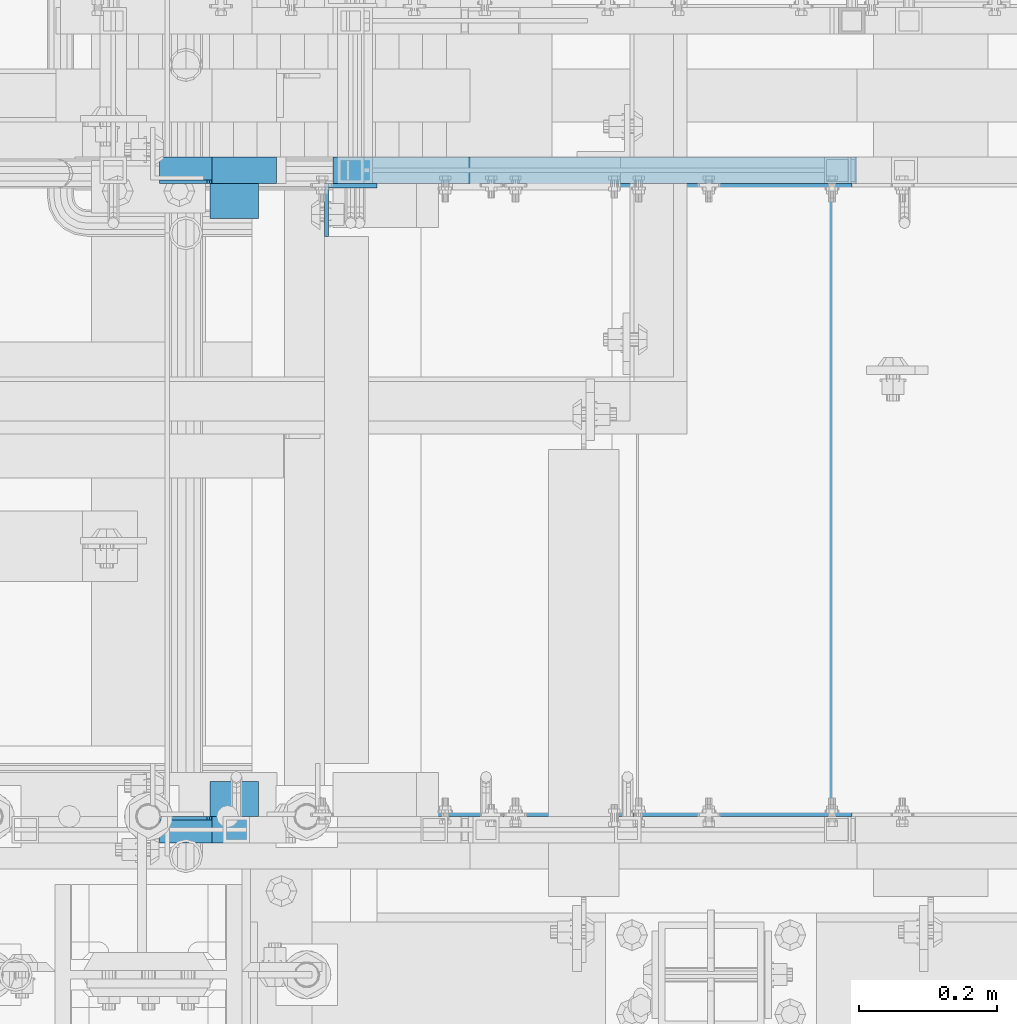
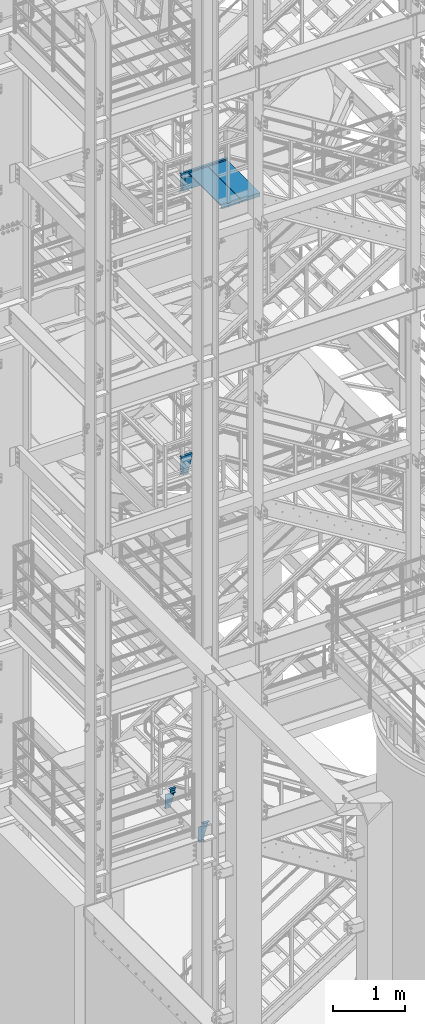
# One storey, part 1137 of 1876: 10 beams, 3 elements without a shape of their own.
"""IFC2X3 building model written with IfcOpenShell, lengths in millimetres."""

from ifc_helpers import new_model, si_unit, frame, origin_with_axes, place, context, subcontext, project, spatial, faceted_brep, material, type_object, element, aggregate, save


model = new_model("IFC2X3")

# Units and contexts
model_context = context("Model", 3, precision=1e-05, world=origin_with_axes())
body_context = subcontext(model_context, "Body", "Model", "MODEL_VIEW")
ifc_project = project(units=[si_unit("LENGTHUNIT", "METRE", prefix="MILLI"), si_unit("AREAUNIT", "SQUARE_METRE"), si_unit("VOLUMEUNIT", "CUBIC_METRE"), si_unit("MASSUNIT", "GRAM", prefix="KILO"), si_unit("TIMEUNIT", "SECOND"), si_unit("PLANEANGLEUNIT", "RADIAN"), si_unit("SOLIDANGLEUNIT", "STERADIAN"), si_unit("THERMODYNAMICTEMPERATUREUNIT", "DEGREE_CELSIUS"), si_unit("LUMINOUSINTENSITYUNIT", "LUMEN")], contexts=[model_context])

# Site, building, storey
site_placement = place(None, origin_with_axes())
site = spatial("IfcSite", under=ifc_project, at=site_placement, CompositionType="ELEMENT")
building_placement = place(site_placement, origin_with_axes())
building = spatial("IfcBuilding", under=site, at=building_placement, Name="Undefined", CompositionType="ELEMENT")
storey_placement = place(building_placement, origin_with_axes())
storey = spatial("IfcBuildingStorey", under=building, at=storey_placement, Name="Undefined", CompositionType="ELEMENT", Elevation=0.0)

# Assembly, beams
assembly_1_placement = place(storey_placement, origin_with_axes())
assembly_1 = element("IfcElementAssembly", 1, at=assembly_1_placement, inside=storey, Name="STRINGER", AssemblyPlace="NOTDEFINED", PredefinedType="RIGID_FRAME")
ifc_material = material(Name="STEEL/A36")
beam_type_1 = type_object("IfcBeamType", PredefinedType="NOTDEFINED")
beam_1_placement = place(assembly_1_placement, frame((2274.88754446459, -6878.63800737594, 15559.8610714293), z_axis=(1.0, 0.0, 0.0), x_axis=(0.0, 1.0, 0.0)))
beam_1 = element("IfcBeam", 2, at=beam_1_placement, type_object=beam_type_1, material=ifc_material, Name="TREAD", context=body_context, shape_type="Brep", body=[
    faceted_brep([(-4.76199999866458, -53.9750000000076, -153.987499894642), (-4.76199999866458, -53.9750000000076, 153.987506208874), (-4.76199999866458, 9.52499999999782, 153.987536726452), (-4.76199999866458, 9.52499999999236, -153.987499894642), (1.33604771690443e-09, -53.9750000000076, -153.987499894642), (1.33604771690443e-09, -53.9750000000076, 153.987506208874), (1.33604771690443e-09, -9.52499999999964, -153.987499894642), (-7.45785655453801e-11, -9.52500000019427, 153.987536621094), (909.637999997837, 9.52499999999236, 153.987506208874), (909.637999997837, 9.52499999999236, -153.987499894642), (0.0, 9.52499999999964, 153.9875), (904.876000067055, 9.52500000238433, 153.987505677049), (909.637999997837, -53.9750000000076, -153.987499894642), (904.875999997837, -53.9750000000076, -153.987499894642), (904.875999997837, -9.52499999999964, -153.9875), (904.875999997837, -9.52499999999964, 153.987506208874), (904.875999997837, -53.9750000000076, 153.987506208874), (909.637999997837, -53.9750000000076, 153.987506208874)], [[[0, 1, 2, 3]], [[1, 0, 4, 5]], [[5, 4, 6, 7]], [[8, 9, 3, 2, 10, 11]], [[12, 13, 14, 6, 4, 0, 3, 9]], [[15, 7, 6, 14]], [[16, 13, 12, 17]], [[13, 16, 15, 14]], [[17, 12, 9, 8]], [[11, 10, 2, 1, 5, 7, 15, 16, 17, 8]]]),
])
beam_2_placement = place(assembly_1_placement, frame((2589.21253777162, -6878.63800737594, 15559.8518518518), z_axis=(1.0, 0.0, 0.0), x_axis=(0.0, 1.0, 0.0)))
beam_2 = element("IfcBeam", 3, at=beam_2_placement, type_object=beam_type_1, material=ifc_material, Name="TREAD", context=body_context, shape_type="Brep", body=[
    faceted_brep([(-4.76199999866458, -53.9750000000076, -153.987499894642), (-4.76199999866458, -53.9750000000076, 153.987506208874), (-4.76199999866458, 9.52499999999782, 153.987536726452), (-4.76199999866458, 9.52499999999236, -153.987499894642), (1.33604771690443e-09, -53.9750000000076, -153.987499894642), (1.33604771690443e-09, -53.9750000000076, 153.987506208874), (1.33604771690443e-09, -9.52499999999964, -153.987499894642), (-7.45785655453801e-11, -9.52500000019427, 153.987536621094), (909.637999997837, 9.52499999999236, 153.987506208874), (909.637999997837, 9.52499999999236, -153.987499894642), (0.0, 9.52499999999964, 153.9875), (904.876000067055, 9.52500000238433, 153.987505677049), (909.637999997837, -53.9750000000076, -153.987499894642), (904.875999997837, -53.9750000000076, -153.987499894642), (904.875999997837, -9.52499999999964, -153.9875), (904.875999997837, -9.52499999999964, 153.987506208874), (904.875999997837, -53.9750000000076, 153.987506208874), (909.637999997837, -53.9750000000076, 153.987506208874)], [[[0, 1, 2, 3]], [[1, 0, 4, 5]], [[5, 4, 6, 7]], [[8, 9, 3, 2, 10, 11]], [[12, 13, 14, 6, 4, 0, 3, 9]], [[15, 7, 6, 14]], [[16, 13, 12, 17]], [[13, 16, 15, 14]], [[17, 12, 9, 8]], [[11, 10, 2, 1, 5, 7, 15, 16, 17, 8]]]),
])

assembly_2_placement = place(storey_placement, origin_with_axes())
assembly_2 = element("IfcElementAssembly", 4, at=assembly_2_placement, inside=storey, Name="STRINGER", AssemblyPlace="NOTDEFINED", PredefinedType="RIGID_FRAME")
beam_type_2 = type_object("IfcBeamType", Name="L2X2X1/4", PredefinedType="NOTDEFINED")
beam_3_placement = place(assembly_2_placement, frame((1885.95000610613, -6857.99999887863, 5105.4), z_axis=(0.0, 1.0, 0.0), x_axis=(-1.0, 0.0, 0.0)))
beam_3 = element("IfcBeam", 5, at=beam_3_placement, type_object=beam_type_2, material=ifc_material, Name="ANGLE", ObjectType="L2X2X1/4", context=body_context, shape_type="Brep", body=[
    faceted_brep([(0.0, 25.3999999999996, -25.3999999999996), (0.0, 25.3999999999996, 25.3999999999996), (69.8499999999992, 25.3999999999996, 25.3999999999996), (69.8499999999992, 25.3999999999996, -25.3999999999996), (0.0, 19.0500000000002, 25.3999999999996), (69.8499999999992, 19.0500000000002, 25.3999999999996), (0.0, 19.0499992349996, -19.0499992350001), (69.8499999999992, 19.0500000000002, -19.0500000000002), (0.0, -25.3999999999996, -19.0500000000002), (69.8499999999992, -25.3999999999996, -19.0500000000002), (0.0, -25.3999999999996, -25.3999999999996), (69.8499999999992, -25.3999999999996, -25.3999999999996)], [[[0, 1, 2, 3]], [[1, 4, 5, 2]], [[4, 6, 7, 5]], [[6, 8, 9, 7]], [[8, 10, 11, 9]], [[10, 0, 3, 11]], [[5, 7, 9, 11, 3, 2]], [[10, 8, 6, 4, 1, 0]]]),
])
beam_4_placement = place(assembly_2_placement, frame((1816.10000610613, -5994.40000114081, 5105.4), z_axis=(0.0, -1.0, 0.0), x_axis=(1.0, 0.0, 0.0)))
beam_4 = element("IfcBeam", 6, at=beam_4_placement, type_object=beam_type_2, material=ifc_material, Name="ANGLE", ObjectType="L2X2X1/4", context=body_context, shape_type="Brep", body=[
    faceted_brep([(0.0, 25.3999999999996, -25.3999999999996), (0.0, 25.3999999999996, 25.3999999999996), (69.8499999999992, 25.3999999999996, 25.3999999999996), (69.8499999999992, 25.3999999999996, -25.3999999999996), (0.0, 19.0500000000002, 25.3999999999996), (69.8499999999992, 19.0500000000002, 25.3999999999996), (0.0, 19.0499992349996, -19.0499992350001), (69.8499999999992, 19.0500000000002, -19.0500000000002), (0.0, -25.3999999999996, -19.0500000000002), (69.8499999999992, -25.3999999999996, -19.0500000000002), (0.0, -25.3999999999996, -25.3999999999996), (69.8499999999992, -25.3999999999996, -25.3999999999996)], [[[0, 1, 2, 3]], [[1, 4, 5, 2]], [[4, 6, 7, 5]], [[6, 8, 9, 7]], [[8, 10, 11, 9]], [[10, 0, 3, 11]], [[5, 7, 9, 11, 3, 2]], [[10, 8, 6, 4, 1, 0]]]),
])

# Beam
beam_type_3 = type_object("IfcBeamType", Name="L3X3X1/4", PredefinedType="NOTDEFINED")
beam_5_placement = place(assembly_1_placement, frame((2019.3, -6007.10000114873, 15537.6268518519), z_axis=(1.0, 0.0, 0.0), x_axis=(0.0, 0.0, -1.0)))
beam_5 = element("IfcBeam", 7, at=beam_5_placement, type_object=beam_type_3, material=ifc_material, Name="ANGLE", ObjectType="L3X3X1/4", context=body_context, shape_type="Brep", body=[
    faceted_brep([(0.0, 38.1000000000004, -38.1), (0.0, 38.1000000000004, 38.1), (152.4, 38.1000000000004, 38.1), (152.4, 38.1000000000004, -38.1), (0.0, 31.75, 38.1000000000004), (152.4, 31.75, 38.0999999999999), (0.0, 31.75, -31.75), (152.4, 31.75, -31.75), (0.0, -38.1000000000004, -31.75), (152.4, -38.1000000000004, -31.75), (0.0, -38.1000000000004, -38.1), (152.4, -38.1000000000004, -38.1)], [[[0, 1, 2, 3]], [[1, 4, 5, 2]], [[4, 6, 7, 5]], [[6, 8, 9, 7]], [[8, 10, 11, 9]], [[10, 0, 3, 11]], [[5, 7, 9, 11, 3, 2]], [[10, 8, 6, 4, 1, 0]]]),
])

# Assembly, beam
assembly_3_placement = place(storey_placement, origin_with_axes())
assembly_3 = element("IfcElementAssembly", 8, at=assembly_3_placement, inside=storey, Name="STRINGER", AssemblyPlace="NOTDEFINED", PredefinedType="RIGID_FRAME")
beam_6_placement = place(assembly_3_placement, frame((2019.30000034225, -6007.10000114766, 10709.2750009577), z_axis=(1.0, 0.0, 0.0), x_axis=(0.0, 0.0, -1.0)))
beam_6 = element("IfcBeam", 9, at=beam_6_placement, type_object=beam_type_3, material=ifc_material, Name="ANGLE", ObjectType="L3X3X1/4", context=body_context, shape_type="Brep", body=[
    faceted_brep([(44.4500003720841, 31.75, -31.75), (44.4500003720841, 38.1000000000004, -31.7499984732442), (0.0, 38.1000000000004, -31.7499984732442), (0.0, 31.75, -31.75), (44.4500003720877, 31.75, 38.1000000008769), (44.4500003720877, 38.1000000000004, 38.1000000000001), (152.4, 31.75, -31.75), (152.4, 31.75, 38.0999999999999), (44.4500003720841, -38.1000000000004, -31.75), (0.0, -38.1000000000004, -31.75), (0.0, -38.1000000000004, -38.1), (152.4, -38.1000000000004, -38.1), (152.4, -38.1000000000004, -31.75), (0.0, 38.1000000000004, -38.1), (152.4, 38.1000000000004, -38.1), (152.4, 38.1000000000004, 38.1)], [[[0, 1, 2, 3]], [[4, 5, 1, 0]], [[6, 7, 4, 0]], [[8, 9, 10, 11, 12]], [[10, 13, 14, 11]], [[7, 6, 12, 11, 14, 15]], [[0, 3, 9, 8, 12, 6]], [[13, 10, 9, 3, 2]], [[15, 14, 13, 2, 1, 5]], [[7, 15, 5, 4]]]),
])

# Beam
beam_type_4 = type_object("IfcBeamType", Name="MC12X10.6", PredefinedType="NOTDEFINED")
beam_7_placement = place(assembly_1_placement, frame((2750.43044530185, -5949.95000114873, 15442.3768518519), z_axis=(0.0, 0.0, 1.0), x_axis=(-1.0, 0.0, 0.0)))
beam_7 = element("IfcBeam", 10, at=beam_7_placement, type_object=beam_type_4, material=ifc_material, Name="STRINGER", ObjectType="MC12X10.6", context=body_context, shape_type="Brep", body=[
    faceted_brep([(86.7653251990796, 19.0500000000002, -152.400000000001), (-1.68647966347635e-06, 19.0500000000002, 152.400000000001), (756.530445301846, 19.0500000000002, 152.4), (756.530445301846, 19.0500000000002, -152.4), (-1.68647966347635e-06, -19.0500000000002, 152.400000000001), (756.530445301846, -19.0500000000002, 152.4), (2.15159765918452, -19.0500000000002, 144.841595000002), (756.530445301846, -19.0500000000002, 144.841595), (2.34044781598368, 14.2875000000004, 144.17817875), (756.530445301846, 14.2875000000004, 144.17817875), (84.4248756966153, 14.2875000000004, -144.17817875), (756.530445301846, 14.2875000000004, -144.17817875), (84.6137258534154, -19.0500000000002, -144.841595000002), (756.530445301846, -19.0500000000002, -144.841595), (86.7653251990796, -19.0500000000002, -152.400000000001), (756.530445301846, -19.0500000000002, -152.4)], [[[0, 1, 2, 3]], [[1, 4, 5, 2]], [[4, 6, 7, 5]], [[6, 8, 9, 7]], [[8, 10, 11, 9]], [[10, 12, 13, 11]], [[12, 14, 15, 13]], [[14, 0, 3, 15]], [[5, 7, 9, 11, 13, 15, 3, 2]], [[14, 12, 10, 8, 6, 4, 1, 0]]]),
])

aggregate(assembly_1, [beam_5, beam_7, beam_1, beam_2])

beam_8_placement = place(assembly_3_placement, frame((2191.60955208303, -5949.95000114766, 10614.0250009577), z_axis=(0.0, 0.0, 1.0), x_axis=(-1.0, 0.0, 0.0)))
beam_8 = element("IfcBeam", 11, at=beam_8_placement, type_object=beam_type_4, material=ifc_material, Name="STRINGER", ObjectType="MC12X10.6", context=body_context, shape_type="Brep", body=[
    faceted_brep([(86.2660262530703, 19.0500000000002, -152.4), (0.0225997770048707, 19.0500000000002, 152.4), (197.709551740775, 19.0500000000002, 152.4), (197.709551740775, 19.0500000000002, -152.4), (0.0225997770048707, -19.0500000000002, 152.4), (197.709551740775, -19.0500000000002, 152.4), (2.16125707980609, -19.0500000000002, 144.841595), (197.709551740775, -19.0500000000002, 144.841595), (2.34897128774537, 14.2875000000004, 144.17817875), (197.709551740775, 14.2875000000004, 144.17817875), (83.9396547423298, 14.2875000000004, -144.17817875), (197.709551740775, 14.2875000000004, -144.17817875), (84.1273689502691, -19.0500000000002, -144.841595), (197.709551740775, -19.0500000000002, -144.841595), (86.2660262530703, -19.0500000000002, -152.4), (197.709551740775, -19.0500000000002, -152.4)], [[[0, 1, 2, 3]], [[1, 4, 5, 2]], [[4, 6, 7, 5]], [[6, 8, 9, 7]], [[8, 10, 11, 9]], [[10, 12, 13, 11]], [[12, 14, 15, 13]], [[14, 0, 3, 15]], [[5, 7, 9, 11, 13, 15, 3, 2]], [[14, 12, 10, 8, 6, 4, 1, 0]]]),
])

aggregate(assembly_3, [beam_6, beam_8])

beam_9_placement = place(assembly_2_placement, frame((1727.20000610872, -6902.45000113476, 5013.32499999939), z_axis=(0.0, 0.0, 1.0), x_axis=(1.0, 0.0, 0.0)))
beam_9 = element("IfcBeam", 12, at=beam_9_placement, type_object=beam_type_4, material=ifc_material, Name="STRINGER", ObjectType="MC12X10.6", context=body_context, shape_type="Brep", body=[
    faceted_brep([(79.3749940820196, 14.2875000000004, 95.2500000000018), (79.3749940820196, 19.0500000000002, 95.2500000000018), (15.8749938912845, 19.0500000000002, 95.2500000000018), (15.8749938912845, 14.2875000000004, 95.2500000000018), (84.2350736000651, 14.2875000000004, 96.2167299225894), (84.2350736000651, 19.0500000000002, 96.2167299225894), (88.3552500682188, 14.2875000000004, 98.9697438230678), (88.3552500682188, 19.0500000000002, 98.9697438230678), (91.108263968697, 14.2875000000004, 103.089920291221), (91.108263968697, 19.0500000000002, 103.089920291221), (92.0749938912847, 14.2875000000004, 107.949999809267), (92.0749938912847, 19.0500000000002, 107.949999809267), (92.0749938912847, -19.0500000000002, 152.4), (92.0749938912847, 19.0500000000002, 152.4), (92.0749938912847, 14.2875000000004, 144.17817875), (92.0749938912847, -19.0500000000002, 144.841595), (15.8749938912845, 14.2875000000004, -144.17817875), (15.8749938912845, -19.0500000000002, -144.841595), (98.8452989766126, -19.0500000000002, -144.841595), (99.0379841014576, 14.2875000000004, -144.17817875), (15.8749938912845, -19.0500000000002, -152.4), (96.6500072407634, -19.0500000000002, -152.4), (15.8749938912845, 19.0500000000002, -152.4), (96.6500072407634, 19.0500000000002, -152.4), (185.177272065402, -19.0500000000002, 152.4), (182.981980329553, -19.0500000000002, 144.841595), (182.789295204708, 14.2875000000004, 144.17817875), (185.177272065402, 19.0500000000002, 152.4)], [[[0, 1, 2, 3]], [[4, 5, 1, 0]], [[6, 7, 5, 4]], [[8, 9, 7, 6]], [[10, 11, 9, 8]], [[12, 13, 11, 10, 14, 15]], [[16, 17, 18, 19]], [[17, 20, 21, 18]], [[20, 22, 23, 21]], [[24, 25, 26, 19, 18, 21, 23, 27]], [[25, 24, 12, 15]], [[26, 25, 15, 14]], [[8, 6, 4, 0, 3, 16, 19, 26, 14, 10]], [[22, 20, 17, 16, 3, 2]], [[27, 23, 22, 2, 1, 5, 7, 9, 11, 13]], [[24, 27, 13, 12]]]),
])

beam_10_placement = place(assembly_2_placement, frame((1912.37727816872, -5949.95000113562, 5013.32500000023), z_axis=(0.0, 0.0, 1.0), x_axis=(-1.0, 0.0, 0.0)))
beam_10 = element("IfcBeam", 13, at=beam_10_placement, type_object=beam_type_4, material=ifc_material, Name="STRINGER", ObjectType="MC12X10.6", context=body_context, shape_type="Brep", body=[
    faceted_brep([(93.1022781687177, -19.0500000000002, 152.4), (93.1022781687177, -19.0500000000002, 144.841595), (93.1022781687177, 14.2875000000004, 144.17817875), (93.1022781687177, 14.2875000000004, 107.949999809267), (93.1022781687177, 19.0500000000002, 107.949999809267), (93.1022781687177, 19.0500000000002, 152.4), (94.0690080913055, 14.2875000000004, 103.089920291221), (94.0690080913055, 19.0500000000002, 103.089920291221), (96.8220219917837, 14.2875000000004, 98.9697438230678), (96.8220219917837, 19.0500000000002, 98.9697438230678), (100.942198459937, 14.2875000000004, 96.2167299225894), (100.942198459937, 19.0500000000002, 96.2167299225894), (105.802277977983, 14.2875000000004, 95.2500000000018), (105.802277977983, 19.0500000000002, 95.2500000000018), (169.302278168718, 14.2875000000004, 95.2500000000018), (169.302278168718, 19.0500000000002, 95.2500000000018), (88.527264823621, -19.0500000000002, -152.4), (86.3319730877715, -19.0500000000002, -144.841595), (86.1392879629268, 14.2875000000004, -144.17817875), (2.38797685967643, 14.2875000000004, 144.17817875), (2.19529173483147, -19.0500000000002, 144.841595), (-1.68647966347635e-06, -19.0500000000002, 152.400000000001), (-1.68647966347635e-06, 19.0500000000002, 152.400000000001), (88.527264823621, 19.0500000000002, -152.4), (169.302278168718, 19.0500000000002, -152.4), (169.302278168718, -19.0500000000002, -152.4), (169.302278168718, -19.0500000000002, -144.841595), (169.302278168718, 14.2875000000004, -144.17817875)], [[[0, 1, 2, 3, 4, 5]], [[6, 7, 4, 3]], [[8, 9, 7, 6]], [[10, 11, 9, 8]], [[12, 13, 11, 10]], [[14, 15, 13, 12]], [[16, 17, 18, 19, 20, 21, 22, 23]], [[16, 23, 24, 25]], [[17, 16, 25, 26]], [[18, 17, 26, 27]], [[10, 8, 6, 3, 2, 19, 18, 27, 14, 12]], [[20, 19, 2, 1]], [[21, 20, 1, 0]], [[22, 21, 0, 5]], [[24, 23, 22, 5, 4, 7, 9, 11, 13, 15]], [[27, 26, 25, 24, 15, 14]]]),
])

aggregate(assembly_2, [beam_3, beam_4, beam_9, beam_10])

save(model, "model.ifc")
